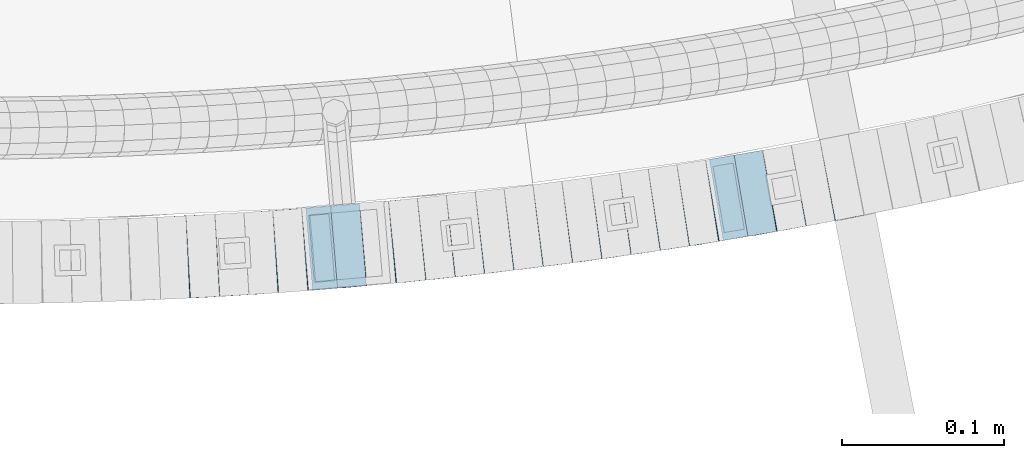
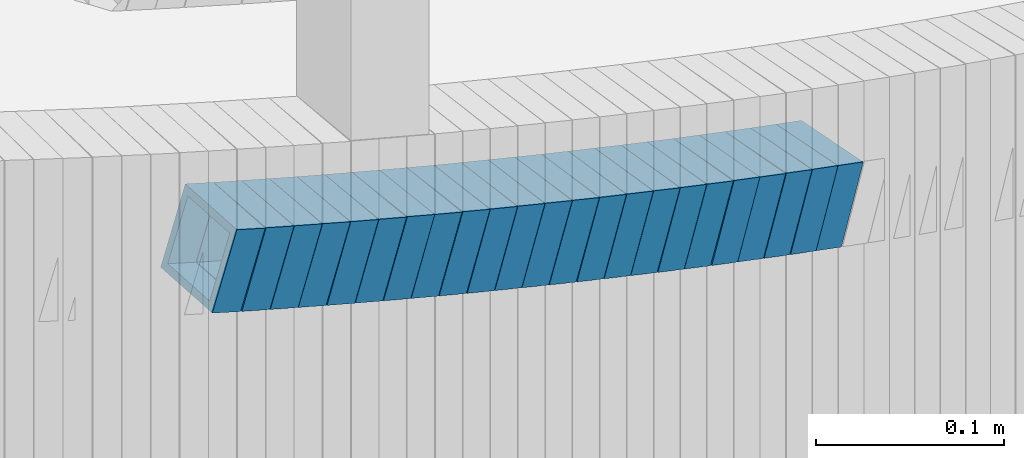
# One storey, part 681 of 975: 23 beams.
"""IFC2X3 building model written with IfcOpenShell, lengths in millimetres."""

from ifc_helpers import new_model, si_unit, frame, origin_with_axes, place, context, subcontext, project, spatial, faceted_brep, material, type_object, element, save


model = new_model("IFC2X3")

# Units and contexts
model_context = context("Model", 3, precision=1e-05, world=origin_with_axes())
body_context = subcontext(model_context, "Body", "Model", "MODEL_VIEW")
ifc_project = project(units=[si_unit("LENGTHUNIT", "METRE", prefix="MILLI"), si_unit("AREAUNIT", "SQUARE_METRE"), si_unit("VOLUMEUNIT", "CUBIC_METRE"), si_unit("MASSUNIT", "GRAM", prefix="KILO"), si_unit("TIMEUNIT", "SECOND"), si_unit("PLANEANGLEUNIT", "RADIAN"), si_unit("SOLIDANGLEUNIT", "STERADIAN"), si_unit("THERMODYNAMICTEMPERATUREUNIT", "DEGREE_CELSIUS"), si_unit("LUMINOUSINTENSITYUNIT", "LUMEN")], contexts=[model_context])

# Site, building, storey
site_placement = place(None, origin_with_axes())
site = spatial("IfcSite", under=ifc_project, at=site_placement, CompositionType="ELEMENT")
building_placement = place(site_placement, origin_with_axes())
building = spatial("IfcBuilding", under=site, at=building_placement, Name="Undefined", CompositionType="ELEMENT")
storey_placement = place(building_placement, origin_with_axes())
storey = spatial("IfcBuildingStorey", under=building, at=storey_placement, Name="Undefined", CompositionType="ELEMENT", Elevation=0.0)

# Beams
ifc_material = material()
beam_type = type_object("IfcBeamType", Name="HSS2X2X.188_TUBES", PredefinedType="NOTDEFINED")
beam_1_placement = place(storey_placement, frame((34870.4301044386, 536.113262485628, 3245.13390484161), z_axis=(-0.0502158966098505, 0.998738386028929, -1.26569375424879e-10), x_axis=(0.95022074331823, 0.0477764620160013, -0.307892755103112)))
element("IfcBeam", 1, at=beam_1_placement, inside=storey, type_object=beam_type, material=ifc_material, Name="WALL", ObjectType="HSS2X2X.188_TUBES", context=body_context, shape_type="Brep", body=[
    faceted_brep([(0.0, 20.6374999999753, -20.6375000000298), (0.0, -20.6375000000153, -20.6375000000153), (18.8433011969464, -20.6374999999898, -20.6375000000226), (18.8433011969719, 20.6375000000007, -20.6374999999862), (0.0, -20.6374999999825, 20.6375000000335), (18.8433011969828, -20.6375000000044, 20.6375000000189), (0.0, 20.6375000000116, 20.6375000000189), (18.8433011970155, 20.6374999999862, 20.6375000000517), (0.0, 25.3999999999724, -25.4000000000342), (0.0, 25.400000000016, 25.4000000000196), (18.8433011970228, 25.3999999999833, 25.4000000000597), (18.8433011969719, 25.4000000000015, -25.3999999999869), (0.0, -25.399999999976, 25.4000000000378), (18.8433011969864, -25.4000000000051, 25.4000000000196), (0.0, -25.400000000016, -25.4000000000196), (18.8433011969391, -25.3999999999869, -25.4000000000269)], [[[0, 1, 2, 3]], [[1, 4, 5, 2]], [[4, 6, 7, 5]], [[6, 0, 3, 7]], [[8, 9, 10, 11]], [[9, 12, 13, 10]], [[12, 14, 15, 13]], [[14, 8, 11, 15]], [[13, 15, 11, 10], [5, 7, 3, 2]], [[14, 12, 9, 8], [6, 4, 1, 0]]]),
])
beam_2_placement = place(storey_placement, frame((34888.7137745596, 536.945328963628, 3239.30572429746), z_axis=(-0.0616800884415425, 0.998095970681098, 1.47140326589579e-10), x_axis=(0.950716893774199, 0.0587521679860489, -0.304443049927697)))
element("IfcBeam", 2, at=beam_2_placement, inside=storey, type_object=beam_type, material=ifc_material, Name="WALL", ObjectType="HSS2X2X.188_TUBES", context=body_context, shape_type="Brep", body=[
    faceted_brep([(0.0, 20.6374999999753, -20.6375000000298), (0.0, -20.6375000000153, -20.6375000000153), (18.724849799155, -20.6375000000171, -20.6374999999425), (18.7248497991204, 20.6374999999989, -20.6375000000007), (0.0, -20.6374999999825, 20.6375000000335), (18.7248497991168, -20.6374999999953, 20.6375000000007), (0.0, 20.6375000000116, 20.6375000000189), (18.724849799084, 20.6375000000226, 20.6374999999498), (0.0, 25.3999999999724, -25.4000000000342), (0.0, 25.400000000016, 25.4000000000196), (18.7248497990731, 25.4000000000269, 25.399999999936), (18.7248497991204, 25.3999999999978, -25.3999999999978), (0.0, -25.399999999976, 25.4000000000378), (18.7248497991186, -25.3999999999942, 25.4000000000051), (0.0, -25.400000000016, -25.4000000000196), (18.7248497991604, -25.4000000000233, -25.3999999999323)], [[[0, 1, 2, 3]], [[1, 4, 5, 2]], [[4, 6, 7, 5]], [[6, 0, 3, 7]], [[8, 9, 10, 11]], [[9, 12, 13, 10]], [[12, 14, 15, 13]], [[14, 8, 11, 15]], [[13, 15, 11, 10], [5, 7, 3, 2]], [[14, 12, 9, 8], [6, 4, 1, 0]]]),
])
beam_3_placement = place(storey_placement, frame((34906.6609009385, 538.011488908519, 3233.60491401757), z_axis=(-0.0672630520254534, 0.997735276429686, -1.11958797788247e-12), x_axis=(0.950405149980547, 0.0640722569986912, -0.304343221993768)))
element("IfcBeam", 3, at=beam_3_placement, inside=storey, type_object=beam_type, material=ifc_material, Name="WALL", ObjectType="HSS2X2X.188_TUBES", context=body_context, shape_type="Brep", body=[
    faceted_brep([(0.0, 20.6374999999753, -20.6375000000298), (0.0, -20.6375000000153, -20.6375000000153), (18.7347271129966, -20.6375000000116, -20.6375000000262), (18.7347271130257, 20.6374999999989, -20.6374999999935), (0.0, -20.6374999999825, 20.6375000000335), (18.7347271129947, -20.6375000000116, 20.6374999999607), (0.0, 20.6375000000116, 20.6375000000189), (18.7347271130147, 20.6375000000007, 20.6374999999898), (0.0, 25.3999999999724, -25.4000000000342), (0.0, 25.400000000016, 25.4000000000196), (18.7347271130166, 25.4000000000015, 25.3999999999905), (18.7347271130257, 25.3999999999996, -25.3999999999869), (0.0, -25.399999999976, 25.4000000000378), (18.7347271129875, -25.4000000000106, 25.3999999999505), (0.0, -25.400000000016, -25.4000000000196), (18.7347271130002, -25.4000000000124, -25.4000000000233)], [[[0, 1, 2, 3]], [[1, 4, 5, 2]], [[4, 6, 7, 5]], [[6, 0, 3, 7]], [[8, 9, 10, 11]], [[9, 12, 13, 10]], [[12, 14, 15, 13]], [[14, 8, 11, 15]], [[13, 15, 11, 10], [5, 7, 3, 2]], [[14, 12, 9, 8], [6, 4, 1, 0]]]),
])
beam_4_placement = place(storey_placement, frame((34924.48592482, 539.169588134654, 3227.94357239759), z_axis=(-0.0728397057101174, 0.997343660566439, -8.36907929624431e-11), x_axis=(0.948514170885777, 0.0692735069916551, -0.30906641496278)))
element("IfcBeam", 4, at=beam_4_placement, inside=storey, type_object=beam_type, material=ifc_material, Name="WALL", ObjectType="HSS2X2X.188_TUBES", context=body_context, shape_type="Brep", body=[
    faceted_brep([(0.0, 20.6374999999753, -20.6375000000298), (0.0, -20.6375000000153, -20.6375000000153), (18.767258723612, -20.6375000000025, -20.6374999999862), (18.7672587236229, 20.6374999999953, -20.637499999968), (0.0, -20.6374999999825, 20.6375000000335), (18.767258723612, -20.6375000000135, 20.6375000000153), (0.0, 20.6375000000116, 20.6375000000189), (18.7672587236266, 20.6374999999844, 20.6375000000371), (0.0, 25.3999999999724, -25.4000000000342), (0.0, 25.400000000016, 25.4000000000196), (18.7672587236302, 25.3999999999814, 25.4000000000342), (18.7672587236229, 25.399999999996, -25.3999999999687), (0.0, -25.399999999976, 25.4000000000378), (18.7672587236157, -25.4000000000142, 25.400000000016), (0.0, -25.400000000016, -25.4000000000196), (18.767258723612, -25.4000000000015, -25.3999999999905)], [[[0, 1, 2, 3]], [[1, 4, 5, 2]], [[4, 6, 7, 5]], [[6, 0, 3, 7]], [[8, 9, 10, 11]], [[9, 12, 13, 10]], [[12, 14, 15, 13]], [[14, 8, 11, 15]], [[13, 15, 11, 10], [5, 7, 3, 2]], [[14, 12, 9, 8], [6, 4, 1, 0]]]),
])
beam_5_placement = place(storey_placement, frame((34942.5835336524, 540.451981683755, 3222.09068496083), z_axis=(-0.0779741640156863, 0.996955380017609, 4.5288288674783e-12), x_axis=(0.950220743373717, 0.0743189410292276, -0.302584259119001)))
element("IfcBeam", 5, at=beam_5_placement, inside=storey, type_object=beam_type, material=ifc_material, Name="WALL", ObjectType="HSS2X2X.188_TUBES", context=body_context, shape_type="Brep", body=[
    faceted_brep([(0.0, 20.6374999999753, -20.6375000000298), (0.0, -20.6375000000153, -20.6375000000153), (18.8433011969464, -20.6374999999898, -20.6375000000226), (18.8433011969719, 20.6375000000007, -20.6374999999862), (0.0, -20.6374999999825, 20.6375000000335), (18.8433011969828, -20.6375000000044, 20.6375000000189), (0.0, 20.6375000000116, 20.6375000000189), (18.8433011970155, 20.6374999999862, 20.6375000000517), (0.0, 25.3999999999724, -25.4000000000342), (0.0, 25.400000000016, 25.4000000000196), (18.8433011970228, 25.3999999999833, 25.4000000000597), (18.8433011969719, 25.4000000000015, -25.3999999999869), (0.0, -25.399999999976, 25.4000000000378), (18.8433011969864, -25.4000000000051, 25.4000000000196), (0.0, -25.400000000016, -25.4000000000196), (18.8433011969391, -25.3999999999869, -25.4000000000269)], [[[0, 1, 2, 3]], [[1, 4, 5, 2]], [[4, 6, 7, 5]], [[6, 0, 3, 7]], [[8, 9, 10, 11]], [[9, 12, 13, 10]], [[12, 14, 15, 13]], [[14, 8, 11, 15]], [[13, 15, 11, 10], [5, 7, 3, 2]], [[14, 12, 9, 8], [6, 4, 1, 0]]]),
])
beam_6_placement = place(storey_placement, frame((34960.6039831528, 541.815257358775, 3216.40206907921), z_axis=(-0.0839720319663465, 0.996468111806616, -5.51881385035813e-12), x_axis=(0.94930970634222, 0.079998009028836, -0.303992434109585)))
element("IfcBeam", 6, at=beam_6_placement, inside=storey, type_object=beam_type, material=ifc_material, Name="WALL", ObjectType="HSS2X2X.188_TUBES", context=body_context, shape_type="Brep", body=[
    faceted_brep([(0.0, 20.6374999999753, -20.6375000000298), (0.0, -20.6375000000153, -20.6375000000153), (18.7547327359644, -20.6374999999844, -20.6375000000553), (18.7547327359898, 20.6375000000171, -20.6375000000335), (0.0, -20.6374999999825, 20.6375000000335), (18.7547327360044, -20.6374999999953, 20.6374999999898), (0.0, 20.6375000000116, 20.6375000000189), (18.7547327360262, 20.6375000000062, 20.6375000000116), (0.0, 25.3999999999724, -25.4000000000342), (0.0, 25.400000000016, 25.4000000000196), (18.7547327360371, 25.4000000000033, 25.4000000000124), (18.7547327359898, 25.4000000000178, -25.4000000000342), (0.0, -25.399999999976, 25.4000000000378), (18.7547327360044, -25.399999999996, 25.3999999999869), (0.0, -25.400000000016, -25.4000000000196), (18.7547327359498, -25.3999999999814, -25.4000000000597)], [[[0, 1, 2, 3]], [[1, 4, 5, 2]], [[4, 6, 7, 5]], [[6, 0, 3, 7]], [[8, 9, 10, 11]], [[9, 12, 13, 10]], [[12, 14, 15, 13]], [[14, 8, 11, 15]], [[13, 15, 11, 10], [5, 7, 3, 2]], [[14, 12, 9, 8], [6, 4, 1, 0]]]),
])
beam_7_placement = place(storey_placement, frame((34978.5786372589, 543.243901968078, 3210.73924107037), z_axis=(-0.0950730065790267, 0.995470302630884, 1.98350335267605e-10), x_axis=(0.946902283782598, 0.0904344879792365, -0.308541193929164)))
element("IfcBeam", 7, at=beam_7_placement, inside=storey, type_object=beam_type, material=ifc_material, Name="WALL", ObjectType="HSS2X2X.188_TUBES", context=body_context, shape_type="Brep", body=[
    faceted_brep([(0.0, 20.6374999999753, -20.6375000000298), (0.0, -20.6375000000153, -20.6375000000153), (18.8047866246379, -20.6374999999916, -20.6375000000298), (18.8047866247143, 20.6374999999844, -20.6374999999643), (0.0, -20.6374999999825, 20.6375000000335), (18.8047866247107, -20.6375000000189, 20.6375000000407), (0.0, 20.6375000000116, 20.6375000000189), (18.8047866247907, 20.6374999999589, 20.6375000001026), (0.0, 25.3999999999724, -25.4000000000342), (0.0, 25.400000000016, 25.4000000000196), (18.8047866248016, 25.3999999999542, 25.4000000001142), (18.8047866247143, 25.3999999999851, -25.3999999999651), (0.0, -25.399999999976, 25.4000000000378), (18.8047866247107, -25.4000000000196, 25.4000000000415), (0.0, -25.400000000016, -25.4000000000196), (18.8047866246197, -25.3999999999887, -25.4000000000378)], [[[0, 1, 2, 3]], [[1, 4, 5, 2]], [[4, 6, 7, 5]], [[6, 0, 3, 7]], [[8, 9, 10, 11]], [[9, 12, 13, 10]], [[12, 14, 15, 13]], [[14, 8, 11, 15]], [[13, 15, 11, 10], [5, 7, 3, 2]], [[14, 12, 9, 8], [6, 4, 1, 0]]]),
])
beam_8_placement = place(storey_placement, frame((34996.5006388738, 544.955553807698, 3204.89983071563), z_axis=(-0.0950730065790267, 0.995470302630884, 1.98350335267605e-10), x_axis=(0.948446844494391, 0.0905820020472163, -0.303716124158317)))
element("IfcBeam", 8, at=beam_8_placement, inside=storey, type_object=beam_type, material=ifc_material, Name="WALL", ObjectType="HSS2X2X.188_TUBES", context=body_context, shape_type="Brep", body=[
    faceted_brep([(0.0, 20.6374999999753, -20.6375000000298), (0.0, -20.6375000000153, -20.6375000000153), (18.767258723612, -20.6375000000025, -20.6374999999862), (18.7672587236229, 20.6374999999953, -20.637499999968), (0.0, -20.6374999999825, 20.6375000000335), (18.767258723612, -20.6375000000135, 20.6375000000153), (0.0, 20.6375000000116, 20.6375000000189), (18.7672587236266, 20.6374999999844, 20.6375000000371), (0.0, 25.3999999999724, -25.4000000000342), (0.0, 25.400000000016, 25.4000000000196), (18.7672587236302, 25.3999999999814, 25.4000000000342), (18.7672587236229, 25.399999999996, -25.3999999999687), (0.0, -25.399999999976, 25.4000000000378), (18.7672587236157, -25.4000000000142, 25.400000000016), (0.0, -25.400000000016, -25.4000000000196), (18.767258723612, -25.4000000000015, -25.3999999999905)], [[[0, 1, 2, 3]], [[1, 4, 5, 2]], [[4, 6, 7, 5]], [[6, 0, 3, 7]], [[8, 9, 10, 11]], [[9, 12, 13, 10]], [[12, 14, 15, 13]], [[14, 8, 11, 15]], [[13, 15, 11, 10], [5, 7, 3, 2]], [[14, 12, 9, 8], [6, 4, 1, 0]]]),
])
beam_9_placement = place(storey_placement, frame((35014.4764000135, 546.586449006769, 3199.23665673552), z_axis=(-0.106138626258718, 0.994351342341283, 7.16145223123021e-11), x_axis=(0.945939087293841, 0.100971026031366, -0.308227343095754)))
element("IfcBeam", 9, at=beam_9_placement, inside=storey, type_object=beam_type, material=ifc_material, Name="WALL", ObjectType="HSS2X2X.188_TUBES", context=body_context, shape_type="Brep", body=[
    faceted_brep([(0.0, 20.6374999999753, -20.6375000000298), (0.0, -20.6375000000153, -20.6375000000153), (18.8225928075335, -20.6374999999935, -20.6375000000298), (18.8225928075699, 20.6374999999898, -20.6374999999825), (0.0, -20.6374999999825, 20.6375000000335), (18.8225928075772, -20.637500000008, 20.6375000000226), (0.0, 20.6375000000116, 20.6375000000189), (18.8225928076135, 20.6374999999753, 20.6375000000698), (0.0, 25.3999999999724, -25.4000000000342), (0.0, 25.400000000016, 25.4000000000196), (18.8225928076281, 25.3999999999705, 25.4000000000815), (18.8225928075663, 25.3999999999905, -25.3999999999796), (0.0, -25.399999999976, 25.4000000000378), (18.8225928075808, -25.4000000000087, 25.4000000000233), (0.0, -25.400000000016, -25.4000000000196), (18.8225928075226, -25.3999999999905, -25.4000000000378)], [[[0, 1, 2, 3]], [[1, 4, 5, 2]], [[4, 6, 7, 5]], [[6, 0, 3, 7]], [[8, 9, 10, 11]], [[9, 12, 13, 10]], [[12, 14, 15, 13]], [[14, 8, 11, 15]], [[13, 15, 11, 10], [5, 7, 3, 2]], [[14, 12, 9, 8], [6, 4, 1, 0]]]),
])
beam_10_placement = place(storey_placement, frame((35032.5472178226, 548.472749573657, 3193.39596826856), z_axis=(-0.111656944986629, 0.993746812138913, -9.1649781097658e-12), x_axis=(0.946955881147291, 0.106399537016546, -0.303238681047161)))
element("IfcBeam", 10, at=beam_10_placement, inside=storey, type_object=beam_type, material=ifc_material, Name="WALL", ObjectType="HSS2X2X.188_TUBES", context=body_context, shape_type="Brep", body=[
    faceted_brep([(0.0, 20.6374999999753, -20.6375000000298), (0.0, -20.6375000000153, -20.6375000000153), (18.8047866246379, -20.6374999999916, -20.6375000000298), (18.8047866247143, 20.6374999999844, -20.6374999999643), (0.0, -20.6374999999825, 20.6375000000335), (18.8047866247107, -20.6375000000189, 20.6375000000407), (0.0, 20.6375000000116, 20.6375000000189), (18.8047866247907, 20.6374999999589, 20.6375000001026), (0.0, 25.3999999999724, -25.4000000000342), (0.0, 25.400000000016, 25.4000000000196), (18.8047866248016, 25.3999999999542, 25.4000000001142), (18.8047866247143, 25.3999999999851, -25.3999999999651), (0.0, -25.399999999976, 25.4000000000378), (18.8047866247107, -25.4000000000196, 25.4000000000415), (0.0, -25.400000000016, -25.4000000000196), (18.8047866246197, -25.3999999999887, -25.4000000000378)], [[[0, 1, 2, 3]], [[1, 4, 5, 2]], [[4, 6, 7, 5]], [[6, 0, 3, 7]], [[8, 9, 10, 11]], [[9, 12, 13, 10]], [[12, 14, 15, 13]], [[14, 8, 11, 15]], [[13, 15, 11, 10], [5, 7, 3, 2]], [[14, 12, 9, 8], [6, 4, 1, 0]]]),
])
beam_11_placement = place(storey_placement, frame((35050.496441305, 550.446960923554, 3187.69454788426), z_axis=(-0.117164953610445, 0.99311246777264, -1.14560407382669e-10), x_axis=(0.946406940559027, 0.111654750947976, -0.303062896858799)))
element("IfcBeam", 11, at=beam_11_placement, inside=storey, type_object=beam_type, material=ifc_material, Name="WALL", ObjectType="HSS2X2X.188_TUBES", context=body_context, shape_type="Brep", body=[
    faceted_brep([(0.0, 20.6374999999753, -20.6375000000298), (0.0, -20.6375000000153, -20.6375000000153), (18.8066477608099, -20.6374999999862, -20.6375000000116), (18.8066477608172, 20.6375000000062, -20.6374999999971), (0.0, -20.6374999999825, 20.6375000000335), (18.8066477608463, -20.6375000000062, 20.6375000000407), (0.0, 20.6375000000116, 20.6375000000189), (18.8066477608536, 20.6374999999844, 20.637500000048), (0.0, 25.3999999999724, -25.4000000000342), (0.0, 25.400000000016, 25.4000000000196), (18.8066477608591, 25.3999999999814, 25.400000000056), (18.8066477608154, 25.4000000000051, -25.4000000000015), (0.0, -25.399999999976, 25.4000000000378), (18.8066477608518, -25.4000000000087, 25.4000000000451), (0.0, -25.400000000016, -25.4000000000196), (18.8066477608081, -25.3999999999851, -25.4000000000196)], [[[0, 1, 2, 3]], [[1, 4, 5, 2]], [[4, 6, 7, 5]], [[6, 0, 3, 7]], [[8, 9, 10, 11]], [[9, 12, 13, 10]], [[12, 14, 15, 13]], [[14, 8, 11, 15]], [[13, 15, 11, 10], [5, 7, 3, 2]], [[14, 12, 9, 8], [6, 4, 1, 0]]]),
])
beam_12_placement = place(storey_placement, frame((35068.3244554965, 552.507082808113, 3182.03226669279), z_axis=(-0.122662172164673, 0.992448483055843, 5.06356627738569e-11), x_axis=(0.94430040422473, 0.116711286027776, -0.307693390073225)))
element("IfcBeam", 12, at=beam_12_placement, inside=storey, type_object=beam_type, material=ifc_material, Name="WALL", ObjectType="HSS2X2X.188_TUBES", context=body_context, shape_type="Brep", body=[
    faceted_brep([(0.0, 20.6374999999753, -20.6375000000298), (0.0, -20.6375000000153, -20.6375000000153), (18.8480768248774, -20.6374999999716, -20.6375000000735), (18.8480768249356, 20.6375000000153, -20.6375000000226), (0.0, -20.6374999999825, 20.6375000000335), (18.8480768249283, -20.6374999999935, 20.6374999999716), (0.0, 20.6375000000116, 20.6375000000189), (18.8480768249865, 20.6374999999935, 20.6375000000262), (0.0, 25.3999999999724, -25.4000000000342), (0.0, 25.400000000016, 25.4000000000196), (18.848076825001, 25.3999999999887, 25.4000000000378), (18.8480768249392, 25.4000000000142, -25.4000000000233), (0.0, -25.399999999976, 25.4000000000378), (18.8480768249283, -25.399999999996, 25.3999999999833), (0.0, -25.400000000016, -25.4000000000196), (18.8480768248664, -25.3999999999687, -25.4000000000779)], [[[0, 1, 2, 3]], [[1, 4, 5, 2]], [[4, 6, 7, 5]], [[6, 0, 3, 7]], [[8, 9, 10, 11]], [[9, 12, 13, 10]], [[12, 14, 15, 13]], [[14, 8, 11, 15]], [[13, 15, 11, 10], [5, 7, 3, 2]], [[14, 12, 9, 8], [6, 4, 1, 0]]]),
])
beam_13_placement = place(storey_placement, frame((35086.2741217072, 554.682454903768, 3176.23066836195), z_axis=(-0.128148123100254, 0.991755039586834, 4.92400431539863e-11), x_axis=(0.943703010222231, 0.121939153028714, -0.307498734072418)))
element("IfcBeam", 13, at=beam_13_placement, inside=storey, type_object=beam_type, material=ifc_material, Name="WALL", ObjectType="HSS2X2X.188_TUBES", context=body_context, shape_type="Brep", body=[
    faceted_brep([(0.0, 20.6374999999753, -20.6375000000298), (0.0, -20.6375000000153, -20.6375000000153), (18.8565638439322, -20.6375000000116, -20.6374999999643), (18.8565638439395, 20.637499999988, -20.6374999999534), (0.0, -20.6374999999825, 20.6375000000335), (18.856563843914, -20.6374999999953, 20.6375000000116), (0.0, 20.6375000000116, 20.6375000000189), (18.8565638439177, 20.6375000000007, 20.6375000000226), (0.0, 25.3999999999724, -25.4000000000342), (0.0, 25.400000000016, 25.4000000000196), (18.8565638439177, 25.4000000000033, 25.4000000000233), (18.8565638439468, 25.3999999999851, -25.3999999999505), (0.0, -25.399999999976, 25.4000000000378), (18.8565638439104, -25.399999999996, 25.4000000000087), (0.0, -25.400000000016, -25.4000000000196), (18.8565638439395, -25.4000000000124, -25.3999999999614)], [[[0, 1, 2, 3]], [[1, 4, 5, 2]], [[4, 6, 7, 5]], [[6, 0, 3, 7]], [[8, 9, 10, 11]], [[9, 12, 13, 10]], [[12, 14, 15, 13]], [[14, 8, 11, 15]], [[13, 15, 11, 10], [5, 7, 3, 2]], [[14, 12, 9, 8], [6, 4, 1, 0]]]),
])
beam_14_placement = place(storey_placement, frame((35104.344986852, 556.975068076749, 3170.38989477378), z_axis=(-0.133622336458029, 0.991032326011365, 1.43571469379822e-10), x_axis=(0.94460617717432, 0.127362631023503, -0.302486248055823)))
element("IfcBeam", 14, at=beam_14_placement, inside=storey, type_object=beam_type, material=ifc_material, Name="WALL", ObjectType="HSS2X2X.188_TUBES", context=body_context, shape_type="Brep", body=[
    faceted_brep([(0.0, 20.6374999999753, -20.6375000000298), (0.0, -20.6375000000153, -20.6375000000153), (18.8433011969464, -20.6374999999898, -20.6375000000226), (18.8433011969719, 20.6375000000007, -20.6374999999862), (0.0, -20.6374999999825, 20.6375000000335), (18.8433011969828, -20.6375000000044, 20.6375000000189), (0.0, 20.6375000000116, 20.6375000000189), (18.8433011970155, 20.6374999999862, 20.6375000000517), (0.0, 25.3999999999724, -25.4000000000342), (0.0, 25.400000000016, 25.4000000000196), (18.8433011970228, 25.3999999999833, 25.4000000000597), (18.8433011969719, 25.4000000000015, -25.3999999999869), (0.0, -25.399999999976, 25.4000000000378), (18.8433011969864, -25.4000000000051, 25.4000000000196), (0.0, -25.400000000016, -25.4000000000196), (18.8433011969391, -25.3999999999869, -25.4000000000269)], [[[0, 1, 2, 3]], [[1, 4, 5, 2]], [[4, 6, 7, 5]], [[6, 0, 3, 7]], [[8, 9, 10, 11]], [[9, 12, 13, 10]], [[12, 14, 15, 13]], [[14, 8, 11, 15]], [[13, 15, 11, 10], [5, 7, 3, 2]], [[14, 12, 9, 8], [6, 4, 1, 0]]]),
])
beam_15_placement = place(storey_placement, frame((35122.2769084742, 559.344374775699, 3164.70049435878), z_axis=(-0.139854805563569, 0.990172022105642, 1.73225544131128e-10), x_axis=(0.943372970173261, 0.13324477002447, -0.303798075055793)))
element("IfcBeam", 15, at=beam_15_placement, inside=storey, type_object=beam_type, material=ifc_material, Name="WALL", ObjectType="HSS2X2X.188_TUBES", context=body_context, shape_type="Brep", body=[
    faceted_brep([(0.0, 20.6374999999753, -20.6375000000298), (0.0, -20.6375000000153, -20.6375000000153), (18.7555325170906, -20.6374999999916, -20.6374999999971), (18.7555325171452, 20.637499999988, -20.6374999999571), (0.0, -20.6374999999825, 20.6375000000335), (18.7555325170615, -20.6374999999844, 20.6374999999716), (0.0, 20.6375000000116, 20.6375000000189), (18.7555325171015, 20.6374999999953, 20.637500000008), (0.0, 25.3999999999724, -25.4000000000342), (0.0, 25.400000000016, 25.4000000000196), (18.7555325171015, 25.399999999996, 25.4000000000051), (18.7555325171488, 25.3999999999851, -25.3999999999505), (0.0, -25.399999999976, 25.4000000000378), (18.755532517047, -25.3999999999814, 25.3999999999578), (0.0, -25.400000000016, -25.4000000000196), (18.7555325170979, -25.3999999999924, -25.3999999999978)], [[[0, 1, 2, 3]], [[1, 4, 5, 2]], [[4, 6, 7, 5]], [[6, 0, 3, 7]], [[8, 9, 10, 11]], [[9, 12, 13, 10]], [[12, 14, 15, 13]], [[14, 8, 11, 15]], [[13, 15, 11, 10], [5, 7, 3, 2]], [[14, 12, 9, 8], [6, 4, 1, 0]]]),
])
beam_16_placement = place(storey_placement, frame((35140.006458652, 561.805154827608, 3159.03809114399), z_axis=(-0.145333064891573, 0.989382787524233, -1.23623067338485e-11), x_axis=(0.941156564766389, 0.138248986965684, -0.308401585923439)))
element("IfcBeam", 16, at=beam_16_placement, inside=storey, type_object=beam_type, material=ifc_material, Name="WALL", ObjectType="HSS2X2X.188_TUBES", context=body_context, shape_type="Brep", body=[
    faceted_brep([(0.0, 20.6374999999753, -20.6375000000298), (0.0, -20.6375000000153, -20.6375000000153), (18.8066477608099, -20.6374999999862, -20.6375000000116), (18.8066477608172, 20.6375000000062, -20.6374999999971), (0.0, -20.6374999999825, 20.6375000000335), (18.8066477608463, -20.6375000000062, 20.6375000000407), (0.0, 20.6375000000116, 20.6375000000189), (18.8066477608536, 20.6374999999844, 20.637500000048), (0.0, 25.3999999999724, -25.4000000000342), (0.0, 25.400000000016, 25.4000000000196), (18.8066477608591, 25.3999999999814, 25.400000000056), (18.8066477608154, 25.4000000000051, -25.4000000000015), (0.0, -25.399999999976, 25.4000000000378), (18.8066477608518, -25.4000000000087, 25.4000000000451), (0.0, -25.400000000016, -25.4000000000196), (18.8066477608081, -25.3999999999851, -25.4000000000196)], [[[0, 1, 2, 3]], [[1, 4, 5, 2]], [[4, 6, 7, 5]], [[6, 0, 3, 7]], [[8, 9, 10, 11]], [[9, 12, 13, 10]], [[12, 14, 15, 13]], [[14, 8, 11, 15]], [[13, 15, 11, 10], [5, 7, 3, 2]], [[14, 12, 9, 8], [6, 4, 1, 0]]]),
])
beam_17_placement = place(storey_placement, frame((35157.9785121001, 564.402475609701, 3153.19687075264), z_axis=(-0.150797989337356, 0.988564599007981, -2.08924575417768e-10), x_axis=(0.941982549776787, 0.143692252965949, -0.303350312928126)))
element("IfcBeam", 17, at=beam_17_placement, inside=storey, type_object=beam_type, material=ifc_material, Name="WALL", ObjectType="HSS2X2X.188_TUBES", context=body_context, shape_type="Brep", body=[
    faceted_brep([(0.0, 20.6374999999753, -20.6375000000298), (0.0, -20.6375000000153, -20.6375000000153), (18.7853666454903, -20.6375000000535, -20.6375000000326), (18.785366645363, 20.6374999999862, -20.6375000000044), (0.0, -20.6374999999825, 20.6375000000335), (18.785366645352, -20.6375000000007, 20.6374999999989), (0.0, 20.6375000000116, 20.6375000000189), (18.7853666453102, 20.6375000000025, 20.6374999999753), (0.0, 25.3999999999724, -25.4000000000342), (0.0, 25.400000000016, 25.4000000000196), (18.7853666452065, 25.4000000000451, 25.4000000000351), (18.7853666453739, 25.3999999999833, -25.400000000006), (0.0, -25.399999999976, 25.4000000000378), (18.7853666497213, -25.399999993424, 25.3999999995158), (0.0, -25.400000000016, -25.4000000000196), (18.7853666455194, -25.4000000000633, -25.4000000000406)], [[[0, 1, 2, 3]], [[1, 4, 5, 2]], [[4, 6, 7, 5]], [[6, 0, 3, 7]], [[8, 9, 10, 11]], [[9, 12, 13, 10]], [[12, 14, 15, 13]], [[14, 8, 11, 15]], [[13, 15, 11, 10], [5, 7, 3, 2]], [[14, 12, 9, 8], [6, 4, 1, 0]]]),
])
beam_18_placement = place(storey_placement, frame((35175.7085558802, 567.063803178679, 3147.53422585889), z_axis=(-0.156249124112757, 0.987717677888776, 4.1671228245832e-11), x_axis=(0.939722926300728, 0.148656734047574, -0.307931806098534)))
element("IfcBeam", 18, at=beam_18_placement, inside=storey, type_object=beam_type, material=ifc_material, Name="WALL", ObjectType="HSS2X2X.188_TUBES", context=body_context, shape_type="Brep", body=[
    faceted_brep([(0.0, 20.6374999999753, -20.6375000000298), (0.0, -20.6375000000153, -20.6375000000153), (18.8433011969464, -20.6374999999898, -20.6375000000226), (18.8433011969719, 20.6375000000007, -20.6374999999862), (0.0, -20.6374999999825, 20.6375000000335), (18.8433011969828, -20.6375000000044, 20.6375000000189), (0.0, 20.6375000000116, 20.6375000000189), (18.8433011970155, 20.6374999999862, 20.6375000000517), (0.0, 25.3999999999724, -25.4000000000342), (0.0, 25.400000000016, 25.4000000000196), (18.8433011970228, 25.3999999999833, 25.4000000000597), (18.8433011969719, 25.4000000000015, -25.3999999999869), (0.0, -25.399999999976, 25.4000000000378), (18.8433011969864, -25.4000000000051, 25.4000000000196), (0.0, -25.400000000016, -25.4000000000196), (18.8433011969391, -25.3999999999869, -25.4000000000269)], [[[0, 1, 2, 3]], [[1, 4, 5, 2]], [[4, 6, 7, 5]], [[6, 0, 3, 7]], [[8, 9, 10, 11]], [[9, 12, 13, 10]], [[12, 14, 15, 13]], [[14, 8, 11, 15]], [[13, 15, 11, 10], [5, 7, 3, 2]], [[14, 12, 9, 8], [6, 4, 1, 0]]]),
])
for number, where, z_axis, x_axis, name in (
    (19, (35193.8180195834, 569.837029107212, 3141.70322650391), (-0.168030974737274, 0.985781715963956, 2.33967057283735e-10), (0.939084130164916, 0.160071159028112, -0.304135201053413), "WALL"),
    (20, (35211.4180195834, 572.837029107213, 3136.00322650391), (-0.168030974737274, 0.985781715963956, 2.33967057283735e-10), (0.939084130164916, 0.160071159028112, -0.304135201053413), "WALL"),
):
    element("IfcBeam", number, at=place(storey_placement, frame(where, z_axis=z_axis, x_axis=x_axis)), inside=storey, type_object=beam_type, material=ifc_material, Name=name, ObjectType="HSS2X2X.188_TUBES", context=body_context, shape_type="Brep", body=[
        faceted_brep([(0.0, 20.6374999999753, -20.6375000000298), (0.0, -20.6375000000153, -20.6375000000153), (18.7416648140024, -20.6375000000153, -20.6374999999825), (18.7416648139188, 20.6375000000189, -20.6375000000298), (0.0, -20.6374999999825, 20.6375000000335), (18.7416648140097, -20.6375000000189, 20.6375000000226), (0.0, 20.6375000000116, 20.6375000000189), (18.741664813926, 20.6375000000153, 20.6374999999753), (0.0, 25.3999999999724, -25.4000000000342), (0.0, 25.400000000016, 25.4000000000196), (18.7416648139224, 25.4000000000196, 25.3999999999687), (18.7416648139042, 25.4000000000233, -25.4000000000378), (0.0, -25.399999999976, 25.4000000000378), (18.7416648140133, -25.4000000000215, 25.4000000000269), (0.0, -25.400000000016, -25.4000000000196), (18.7416648140133, -25.4000000000196, -25.399999999976)], [[[0, 1, 2, 3]], [[1, 4, 5, 2]], [[4, 6, 7, 5]], [[6, 0, 3, 7]], [[8, 9, 10, 11]], [[9, 12, 13, 10]], [[12, 14, 15, 13]], [[14, 8, 11, 15]], [[13, 15, 11, 10], [5, 7, 3, 2]], [[14, 12, 9, 8], [6, 4, 1, 0]]]),
    ])
beam_19_placement = place(storey_placement, frame((35229.2013286934, 575.782253685414, 3130.3382706792), z_axis=(-0.178885438685502, 0.983869910011631, 2.1800042304676e-10), x_axis=(0.935905451242195, 0.170164628044034, -0.308423387079805)))
element("IfcBeam", 21, at=beam_19_placement, inside=storey, type_object=beam_type, material=ifc_material, Name="WALL", ObjectType="HSS2X2X.188_TUBES", context=body_context, shape_type="Brep", body=[
    faceted_brep([(0.0, 20.6374999999753, -20.6375000000298), (0.0, -20.6375000000153, -20.6375000000153), (18.8066477608099, -20.6374999999862, -20.6375000000116), (18.8066477608172, 20.6375000000062, -20.6374999999971), (0.0, -20.6374999999825, 20.6375000000335), (18.8066477608463, -20.6375000000062, 20.6375000000407), (0.0, 20.6375000000116, 20.6375000000189), (18.8066477608536, 20.6374999999844, 20.637500000048), (0.0, 25.3999999999724, -25.4000000000342), (0.0, 25.400000000016, 25.4000000000196), (18.8066477608591, 25.3999999999814, 25.400000000056), (18.8066477608154, 25.4000000000051, -25.4000000000015), (0.0, -25.399999999976, 25.4000000000378), (18.8066477608518, -25.4000000000087, 25.4000000000451), (0.0, -25.400000000016, -25.4000000000196), (18.8066477608081, -25.3999999999851, -25.4000000000196)], [[[0, 1, 2, 3]], [[1, 4, 5, 2]], [[4, 6, 7, 5]], [[6, 0, 3, 7]], [[8, 9, 10, 11]], [[9, 12, 13, 10]], [[12, 14, 15, 13]], [[14, 8, 11, 15]], [[13, 15, 11, 10], [5, 7, 3, 2]], [[14, 12, 9, 8], [6, 4, 1, 0]]]),
])
beam_20_placement = place(storey_placement, frame((35247.073783161, 578.989155683342, 3124.49662764212), z_axis=(-0.18428853487203, 0.982872186967726, -3.81432982976549e-11), x_axis=(0.936567776700519, 0.175606457943848, -0.303320245903009)))
element("IfcBeam", 22, at=beam_20_placement, inside=storey, type_object=beam_type, material=ifc_material, Name="WALL", ObjectType="HSS2X2X.188_TUBES", context=body_context, shape_type="Brep", body=[
    faceted_brep([(0.0, 20.6374999999753, -20.6375000000298), (0.0, -20.6375000000153, -20.6375000000153), (18.7853666454903, -20.6375000000535, -20.6375000000326), (18.785366645363, 20.6374999999862, -20.6375000000044), (0.0, -20.6374999999825, 20.6375000000335), (18.785366645352, -20.6375000000007, 20.6374999999989), (0.0, 20.6375000000116, 20.6375000000189), (18.7853666453102, 20.6375000000025, 20.6374999999753), (0.0, 25.3999999999724, -25.4000000000342), (0.0, 25.400000000016, 25.4000000000196), (18.7853666452065, 25.4000000000451, 25.4000000000351), (18.7853666453739, 25.3999999999833, -25.400000000006), (0.0, -25.399999999976, 25.4000000000378), (18.7853666497213, -25.399999993424, 25.3999999995158), (0.0, -25.400000000016, -25.4000000000196), (18.7853666455194, -25.4000000000633, -25.4000000000406)], [[[0, 1, 2, 3]], [[1, 4, 5, 2]], [[4, 6, 7, 5]], [[6, 0, 3, 7]], [[8, 9, 10, 11]], [[9, 12, 13, 10]], [[12, 14, 15, 13]], [[14, 8, 11, 15]], [[13, 15, 11, 10], [5, 7, 3, 2]], [[14, 12, 9, 8], [6, 4, 1, 0]]]),
])
beam_21_placement = place(storey_placement, frame((35264.6631807644, 582.279029274417, 3118.80894090825), z_axis=(-0.185305551283163, 0.982680951613311, 1.11998815555125e-10), x_axis=(0.935909172125305, 0.176485730023629, -0.304838988040823)))
element("IfcBeam", 23, at=beam_21_placement, inside=storey, type_object=beam_type, material=ifc_material, Name="WALL", ObjectType="HSS2X2X.188_TUBES", context=body_context, shape_type="Brep", body=[
    faceted_brep([(0.0, 20.6374999999753, -20.6375000000298), (0.0, -20.6375000000153, -20.6375000000153), (18.6959888745805, -20.6374999999771, -20.6375000000407), (18.6959888746751, 20.637499999988, -20.6374999999716), (0.0, -20.6374999999825, 20.6375000000335), (18.6959888746969, -20.6375000000135, 20.6375000000371), (0.0, 20.6375000000116, 20.6375000000189), (18.6959888747988, 20.6374999999498, 20.6375000001062), (0.0, 25.3999999999724, -25.4000000000342), (0.0, 25.400000000016, 25.4000000000196), (18.695988874817, 25.3999999999414, 25.4000000001215), (18.6959888746678, 25.3999999999887, -25.399999999976), (0.0, -25.399999999976, 25.4000000000378), (18.6959888747042, -25.4000000000124, 25.4000000000378), (0.0, -25.400000000016, -25.4000000000196), (18.695988874555, -25.3999999999687, -25.4000000000597)], [[[0, 1, 2, 3]], [[1, 4, 5, 2]], [[4, 6, 7, 5]], [[6, 0, 3, 7]], [[8, 9, 10, 11]], [[9, 12, 13, 10]], [[12, 14, 15, 13]], [[14, 8, 11, 15]], [[13, 15, 11, 10], [5, 7, 3, 2]], [[14, 12, 9, 8], [6, 4, 1, 0]]]),
])

save(model, "model.ifc")
